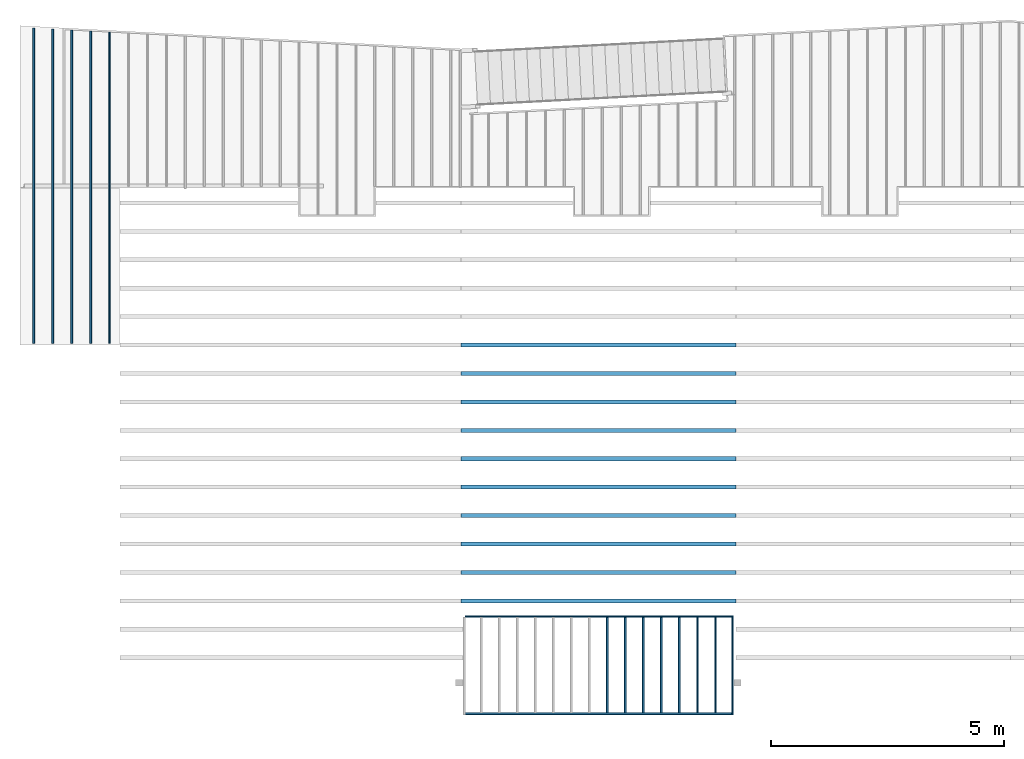
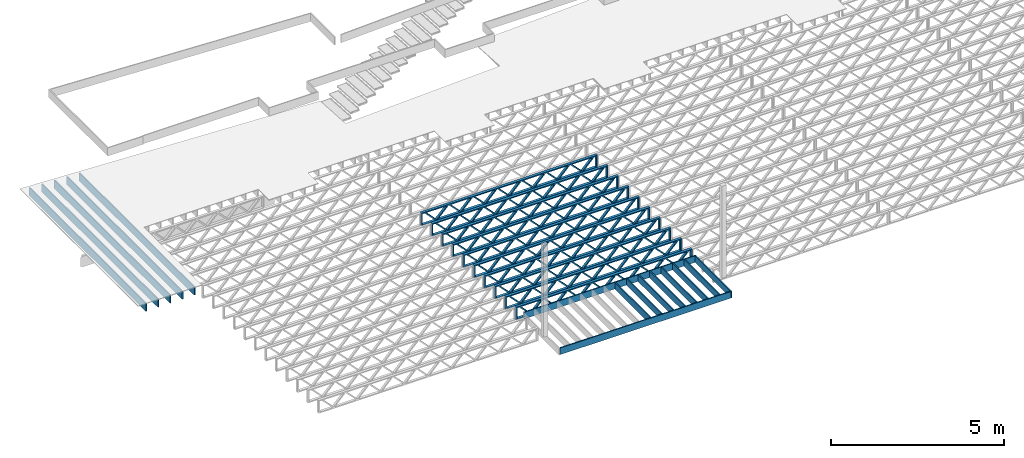
# One storey, part 2 of 23: 25 beams, 3 elements without a shape of their own.
"""IFC4 building model written with IfcOpenShell, lengths in feet."""

from ifc_helpers import new_model, entity, si_unit, converted_unit, derived_unit, direction, frame, frame_2d, origin, origin_2d_with_axis, place, context, subcontext, project, spatial, rectangle, extrude, source, transform, mapped, material, material_profile, profile_set, profile_usage, type_object, type_shapes, element, aggregate, save


model = new_model("IFC4")

# Units and contexts
model_context = context("Model", 3, precision=0.0001, world=origin(), true_north=direction((6.12303176911189e-17, 1.0)))
body_context = subcontext(model_context, "Body", "Model", "MODEL_VIEW")
ifc_project = project(units=[converted_unit("LENGTHUNIT", "FOOT", entity("IfcRatioMeasure", 0.3048), si_unit("LENGTHUNIT", "METRE"), dimensions=[1, 0, 0, 0, 0, 0, 0]), converted_unit("AREAUNIT", "SQUARE FOOT", entity("IfcRatioMeasure", 0.09290304), si_unit("AREAUNIT", "SQUARE_METRE"), dimensions=[2, 0, 0, 0, 0, 0, 0]), converted_unit("VOLUMEUNIT", "CUBIC FOOT", entity("IfcRatioMeasure", 0.028316846592), si_unit("VOLUMEUNIT", "CUBIC_METRE"), dimensions=[3, 0, 0, 0, 0, 0, 0]), converted_unit("PLANEANGLEUNIT", "DEGREE", entity("IfcRatioMeasure", 0.0174532925199433), si_unit("PLANEANGLEUNIT", "RADIAN"), dimensions=[0, 0, 0, 0, 0, 0, 0]), si_unit("MASSUNIT", "GRAM", prefix="KILO"), derived_unit("MASSDENSITYUNIT", [(si_unit("MASSUNIT", "GRAM", prefix="KILO"), 1), (si_unit("LENGTHUNIT", "METRE"), -3)]), derived_unit("MOMENTOFINERTIAUNIT", [(si_unit("LENGTHUNIT", "METRE"), 4)]), si_unit("TIMEUNIT", "SECOND"), si_unit("FREQUENCYUNIT", "HERTZ"), si_unit("THERMODYNAMICTEMPERATUREUNIT", "DEGREE_CELSIUS"), derived_unit("THERMALTRANSMITTANCEUNIT", [(si_unit("MASSUNIT", "GRAM", prefix="KILO"), 1), (si_unit("THERMODYNAMICTEMPERATUREUNIT", "KELVIN"), -1), (si_unit("TIMEUNIT", "SECOND"), -3)]), derived_unit("VOLUMETRICFLOWRATEUNIT", [(si_unit("LENGTHUNIT", "METRE"), 3), (si_unit("TIMEUNIT", "SECOND"), -1)]), si_unit("ELECTRICCURRENTUNIT", "AMPERE"), si_unit("ELECTRICVOLTAGEUNIT", "VOLT"), si_unit("POWERUNIT", "WATT"), si_unit("FORCEUNIT", "NEWTON"), si_unit("ILLUMINANCEUNIT", "LUX"), si_unit("LUMINOUSFLUXUNIT", "LUMEN"), si_unit("LUMINOUSINTENSITYUNIT", "CANDELA"), derived_unit("USERDEFINED", [(si_unit("MASSUNIT", "GRAM", prefix="KILO"), -1), (si_unit("LENGTHUNIT", "METRE"), -2), (si_unit("TIMEUNIT", "SECOND"), 3), (si_unit("LUMINOUSFLUXUNIT", "LUMEN"), 1)]), derived_unit("LINEARVELOCITYUNIT", [(si_unit("LENGTHUNIT", "METRE"), 1), (si_unit("TIMEUNIT", "SECOND"), -1)]), si_unit("PRESSUREUNIT", "PASCAL"), derived_unit("USERDEFINED", [(si_unit("LENGTHUNIT", "METRE"), -2), (si_unit("MASSUNIT", "GRAM", prefix="KILO"), 1), (si_unit("TIMEUNIT", "SECOND"), -2)]), derived_unit("LINEARFORCEUNIT", [(si_unit("MASSUNIT", "GRAM", prefix="KILO"), 1), (si_unit("LENGTHUNIT", "METRE"), 1), (si_unit("TIMEUNIT", "SECOND"), -2), (si_unit("LENGTHUNIT", "METRE"), -1)]), derived_unit("PLANARFORCEUNIT", [(si_unit("MASSUNIT", "GRAM", prefix="KILO"), 1), (si_unit("LENGTHUNIT", "METRE"), 1), (si_unit("TIMEUNIT", "SECOND"), -2), (si_unit("LENGTHUNIT", "METRE"), -2)])], contexts=[model_context])

# Site, building, storey
site_placement = place(None, origin())
site = spatial("IfcSite", under=ifc_project, at=site_placement, CompositionType="ELEMENT")
building_placement = place(site_placement, origin())
building = spatial("IfcBuilding", under=site, at=building_placement, CompositionType="ELEMENT")
storey_placement = place(building_placement, frame((0.0, 0.0, 10.8020833333333)))
storey = spatial("IfcBuildingStorey", under=building, at=storey_placement, Name="2ND FLOOR", CompositionType="ELEMENT", Elevation=10.8020833333333)

# Assembly, beams
assembly_1_placement = place(storey_placement, origin())
assembly_1 = element("IfcElementAssembly", 1, at=assembly_1_placement, inside=storey, Name="Structural Beam System:Structural Framing System", ObjectType="Structural Beam System:Structural Framing System", AssemblyPlace="NOTDEFINED", PredefinedType="BEAM_GRID")
ifc_material_1 = material(Category="Materials")
ifc_material_profile_1 = material_profile(ifc_material_1, rectangle(XDim=0.770833333333333, YDim=0.124999999999994, at=frame_2d((-5.55111512312578e-17, 0.0), x_axis=(1.0, 0.0))))
ifc_profile_set_1 = profile_set([ifc_material_profile_1])
ifc_profile_usage_1 = profile_usage(ifc_profile_set_1, cardinal=8)
beam_type_1 = type_object("IfcBeamType", PredefinedType="BEAM", material=ifc_profile_set_1)
shared_shape_1 = source(origin(), body_context, "Body", "SweptSolid", [
    extrude(rectangle(XDim=0.770833333333333, YDim=0.124999999999994, at=frame_2d((-5.55111512312578e-17, 0.0), x_axis=(1.0, 0.0))), frame((-3.35416666666737, 0.0, 0.0), z_axis=(1.0, 0.0, 0.0), x_axis=(0.0, 0.0, -1.0)), (0.0, 0.0, 1.0), 6.70833333333462),
])
type_shapes(beam_type_1, [shared_shape_1])
beam_1_placement = place(assembly_1_placement, frame((-231.439678851187, 925.341101549318, -0.645833333333433), z_axis=(0.0, 0.0, 1.0), x_axis=(0.0, 1.0, 0.0)))
beam_1 = element("IfcBeam", 2, at=beam_1_placement, type_object=beam_type_1, material=ifc_profile_usage_1, PredefinedType="BEAM", context=body_context, shape_type="MappedRepresentation", body=[
    mapped(shared_shape_1, transform((0.0, 0.0, 0.0), scale=1.0)),
])
ifc_profile_usage_2 = profile_usage(ifc_profile_set_1, cardinal=8)
beam_2_placement = place(assembly_1_placement, frame((-230.172795170628, 925.341101549318, -0.645833333333471), z_axis=(0.0, 0.0, 1.0), x_axis=(0.0, 1.0, 0.0)))
beam_2 = element("IfcBeam", 3, at=beam_2_placement, type_object=beam_type_1, material=ifc_profile_usage_2, PredefinedType="BEAM", context=body_context, shape_type="MappedRepresentation", body=[
    mapped(shared_shape_1, transform((0.0, 0.0, 0.0), scale=1.0)),
])
ifc_profile_usage_3 = profile_usage(ifc_profile_set_1, cardinal=8)
beam_3_placement = place(assembly_1_placement, frame((-228.90591149007, 925.341101549318, -0.645833333333471), z_axis=(0.0, 0.0, 1.0), x_axis=(0.0, 1.0, 0.0)))
beam_3 = element("IfcBeam", 4, at=beam_3_placement, type_object=beam_type_1, material=ifc_profile_usage_3, PredefinedType="BEAM", context=body_context, shape_type="MappedRepresentation", body=[
    mapped(shared_shape_1, transform((0.0, 0.0, 0.0), scale=1.0)),
])
ifc_profile_usage_4 = profile_usage(ifc_profile_set_1, cardinal=8)
beam_4_placement = place(assembly_1_placement, frame((-227.639027809511, 925.341101549318, -0.645833333333471), z_axis=(0.0, 0.0, 1.0), x_axis=(0.0, 1.0, 0.0)))
beam_4 = element("IfcBeam", 5, at=beam_4_placement, type_object=beam_type_1, material=ifc_profile_usage_4, PredefinedType="BEAM", context=body_context, shape_type="MappedRepresentation", body=[
    mapped(shared_shape_1, transform((0.0, 0.0, 0.0), scale=1.0)),
])
ifc_profile_usage_5 = profile_usage(ifc_profile_set_1, cardinal=8)
beam_5_placement = place(assembly_1_placement, frame((-226.372144128953, 925.341101549318, -0.645833333333471), z_axis=(0.0, 0.0, 1.0), x_axis=(0.0, 1.0, 0.0)))
beam_5 = element("IfcBeam", 6, at=beam_5_placement, type_object=beam_type_1, material=ifc_profile_usage_5, PredefinedType="BEAM", context=body_context, shape_type="MappedRepresentation", body=[
    mapped(shared_shape_1, transform((0.0, 0.0, 0.0), scale=1.0)),
])
ifc_profile_usage_6 = profile_usage(ifc_profile_set_1, cardinal=8)
beam_6_placement = place(assembly_1_placement, frame((-225.105260448395, 925.341101549318, -0.645833333333471), z_axis=(0.0, 0.0, 1.0), x_axis=(0.0, 1.0, 0.0)))
beam_6 = element("IfcBeam", 7, at=beam_6_placement, type_object=beam_type_1, material=ifc_profile_usage_6, PredefinedType="BEAM", context=body_context, shape_type="MappedRepresentation", body=[
    mapped(shared_shape_1, transform((0.0, 0.0, 0.0), scale=1.0)),
])
ifc_profile_usage_7 = profile_usage(ifc_profile_set_1, cardinal=8)
beam_7_placement = place(assembly_1_placement, frame((-223.838376767836, 925.341101549319, -0.645833333333471), z_axis=(0.0, 0.0, 1.0), x_axis=(0.0, 1.0, 0.0)))
beam_7 = element("IfcBeam", 8, at=beam_7_placement, type_object=beam_type_1, material=ifc_profile_usage_7, PredefinedType="BEAM", context=body_context, shape_type="MappedRepresentation", body=[
    mapped(shared_shape_1, transform((0.0, 0.0, 0.0), scale=1.0)),
])
aggregate(assembly_1, [beam_1, beam_2, beam_3, beam_4, beam_5, beam_6, beam_7])

assembly_2_placement = place(storey_placement, origin())
assembly_2 = element("IfcElementAssembly", 9, at=assembly_2_placement, inside=storey, Name="Structural Beam System:Structural Framing System", ObjectType="Structural Beam System:Structural Framing System", AssemblyPlace="NOTDEFINED", PredefinedType="BEAM_GRID")
ifc_material_2 = material(Name="WOOD TRUSS", Category="Materials")
ifc_material_profile_2 = material_profile(ifc_material_2, rectangle(XDim=1.73473973950632, YDim=0.125, at=frame_2d((-1.11022302462516e-16, 8.32667268468867e-17), x_axis=(1.0, 0.0))))
ifc_material_profile_3 = material_profile(ifc_material_2, rectangle(XDim=1.73473973950633, YDim=0.125, at=frame_2d((-1.11022302462516e-16, 8.32667268468867e-17), x_axis=(1.0, 0.0))))
ifc_material_profile_4 = material_profile(ifc_material_2, rectangle(XDim=1.73473973950632, YDim=0.125, at=frame_2d((-5.55111512312578e-17, 1.38777878078145e-16), x_axis=(1.0, 0.0))))
ifc_material_profile_5 = material_profile(ifc_material_2, rectangle(XDim=1.73473973950633, YDim=0.125, at=frame_2d((-1.11022302462516e-16, 8.32667268468867e-17), x_axis=(1.0, 0.0))))
ifc_material_profile_6 = material_profile(ifc_material_2, rectangle(XDim=1.73473973950632, YDim=0.125, at=frame_2d((-1.11022302462516e-16, 8.32667268468867e-17), x_axis=(1.0, 0.0))))
ifc_material_profile_7 = material_profile(ifc_material_2, rectangle(XDim=1.73473973950633, YDim=0.125, at=frame_2d((-2.77555756156289e-16, 3.05311331771918e-16), x_axis=(1.0, 0.0))))
ifc_material_profile_8 = material_profile(ifc_material_2, rectangle(XDim=1.73473973950632, YDim=0.124999999999999, at=frame_2d((-3.88578058618805e-16, -2.4980018054066e-16), x_axis=(1.0, 0.0))))
ifc_material_profile_9 = material_profile(ifc_material_2, rectangle(XDim=1.73473973950633, YDim=0.125, at=frame_2d((2.77555756156289e-16, -3.05311331771918e-16), x_axis=(1.0, 0.0))))
ifc_material_profile_10 = material_profile(ifc_material_2, rectangle(XDim=1.73473973950632, YDim=0.124999999999999, at=frame_2d((-1.11022302462516e-16, 8.32667268468867e-17), x_axis=(1.0, 0.0))))
ifc_material_profile_11 = material_profile(ifc_material_2, rectangle(XDim=1.73473973950633, YDim=0.125, at=origin_2d_with_axis()))
ifc_material_profile_12 = material_profile(ifc_material_2, rectangle(XDim=0.124999999999982, YDim=0.291666666666668, at=origin_2d_with_axis()))
ifc_material_profile_13 = material_profile(ifc_material_2, rectangle(XDim=0.124999999999932, YDim=0.291666666666664, at=origin_2d_with_axis()))
ifc_material_profile_14 = material_profile(ifc_material_2, rectangle(XDim=1.25000000000002, YDim=0.29166666666667, at=origin_2d_with_axis()))
ifc_material_profile_15 = material_profile(ifc_material_2, rectangle(XDim=1.25000000000004, YDim=0.291666666666667, at=origin_2d_with_axis()))
ifc_profile_set_2 = profile_set([ifc_material_profile_2, ifc_material_profile_3, ifc_material_profile_4, ifc_material_profile_5, ifc_material_profile_6, ifc_material_profile_7, ifc_material_profile_8, ifc_material_profile_9, ifc_material_profile_10, ifc_material_profile_11, ifc_material_profile_12, ifc_material_profile_13, ifc_material_profile_14, ifc_material_profile_15])
ifc_profile_usage_8 = profile_usage(ifc_profile_set_2, cardinal=8)
beam_type_2 = type_object("IfcBeamType", PredefinedType="BEAM", material=ifc_profile_set_2)
shared_shape_2 = source(origin(), body_context, "Body", "SweptSolid", [
    extrude(rectangle(XDim=1.73473973950632, YDim=0.124999999999999, at=frame_2d((5.55111512312578e-16, 7.21644966006352e-16), x_axis=(1.0, 0.0))), frame((5.95847627016997, -0.145833333333334, 0.0), z_axis=(0.0, 1.0, 0.0), x_axis=(0.693383046997606, 0.0, 0.720569184836762)), (0.0, 0.0, 1.0), 0.291666666666667),
    extrude(rectangle(XDim=1.73473973950633, YDim=0.125, at=origin_2d_with_axis()), frame((4.7081903964967, -0.145833333333334, 0.0), z_axis=(0.0, 1.0, 0.0), x_axis=(0.69338304699761, 0.0, -0.720569184836758)), (0.0, 0.0, 1.0), 0.291666666666666),
    extrude(rectangle(XDim=1.73473973950632, YDim=0.125, at=frame_2d((2.22044604925031e-16, 3.88578058618805e-16), x_axis=(1.0, 0.0))), frame((3.29180960350347, -0.145833333333334, 0.0), z_axis=(0.0, 1.0, 0.0), x_axis=(0.693383046997606, 0.0, 0.720569184836762)), (0.0, 0.0, 1.0), 0.291666666666667),
    extrude(rectangle(XDim=1.73473973950633, YDim=0.125, at=frame_2d((1.11022302462516e-16, -8.32667268468867e-17), x_axis=(1.0, 0.0))), frame((2.0415237298302, -0.145833333333334, 0.0), z_axis=(0.0, 1.0, 0.0), x_axis=(0.69338304699761, 0.0, -0.720569184836758)), (0.0, 0.0, 1.0), 0.291666666666667),
    extrude(rectangle(XDim=1.73473973950632, YDim=0.125, at=frame_2d((-5.55111512312578e-17, 1.38777878078145e-16), x_axis=(1.0, 0.0))), frame((0.625142936836964, -0.145833333333334, 0.0), z_axis=(0.0, 1.0, 0.0), x_axis=(0.693383046997606, 0.0, 0.720569184836762)), (0.0, 0.0, 1.0), 0.291666666666667),
    extrude(rectangle(XDim=1.73473973950633, YDim=0.125, at=frame_2d((-1.11022302462516e-16, 8.32667268468867e-17), x_axis=(1.0, 0.0))), frame((-0.625142936836306, -0.145833333333334, 0.0), z_axis=(0.0, 1.0, 0.0), x_axis=(0.69338304699761, 0.0, -0.720569184836758)), (0.0, 0.0, 1.0), 0.291666666666667),
    extrude(rectangle(XDim=1.73473973950632, YDim=0.125, at=frame_2d((-1.11022302462516e-16, 8.32667268468867e-17), x_axis=(1.0, 0.0))), frame((-2.04152372982954, -0.145833333333334, 0.0), z_axis=(0.0, 1.0, 0.0), x_axis=(0.693383046997606, 0.0, 0.720569184836762)), (0.0, 0.0, 1.0), 0.291666666666667),
    extrude(rectangle(XDim=1.73473973950633, YDim=0.125, at=origin_2d_with_axis()), frame((-3.29180960350281, -0.145833333333334, 0.0), z_axis=(0.0, 1.0, 0.0), x_axis=(0.69338304699761, 0.0, -0.720569184836758)), (0.0, 0.0, 1.0), 0.291666666666667),
    extrude(rectangle(XDim=1.73473973950632, YDim=0.124999999999999, at=frame_2d((-1.11022302462516e-16, 8.32667268468867e-17), x_axis=(1.0, 0.0))), frame((-4.70819039649604, -0.145833333333334, 0.0), z_axis=(0.0, 1.0, 0.0), x_axis=(0.693383046997606, 0.0, 0.720569184836762)), (0.0, 0.0, 1.0), 0.291666666666667),
    extrude(rectangle(XDim=1.73473973950633, YDim=0.125, at=frame_2d((-5.55111512312578e-16, 6.38378239159465e-16), x_axis=(1.0, 0.0))), frame((-5.95847627016931, -0.145833333333334, 0.0), z_axis=(0.0, 1.0, 0.0), x_axis=(0.69338304699761, 0.0, -0.720569184836758)), (0.0, 0.0, 1.0), 0.291666666666666),
    extrude(rectangle(XDim=1.73473973950632, YDim=0.125, at=frame_2d((-7.21644966006352e-16, -5.82867087928207e-16), x_axis=(1.0, 0.0))), frame((8.62514293683647, -0.145833333333334, 0.0), z_axis=(0.0, 1.0, 0.0), x_axis=(0.693383046997607, 0.0, 0.720569184836761)), (0.0, 0.0, 1.0), 0.291666666666667),
    extrude(rectangle(XDim=1.73473973950633, YDim=0.125, at=origin_2d_with_axis()), frame((7.3748570631632, -0.145833333333334, 0.0), z_axis=(0.0, 1.0, 0.0), x_axis=(0.69338304699761, 0.0, -0.720569184836758)), (0.0, 0.0, 1.0), 0.291666666666666),
    extrude(rectangle(XDim=1.73473973950632, YDim=0.124999999999999, at=frame_2d((-1.11022302462516e-16, 8.32667268468867e-17), x_axis=(1.0, 0.0))), frame((-7.37485706316255, -0.145833333333334, 0.0), z_axis=(0.0, 1.0, 0.0), x_axis=(0.693383046997606, 0.0, 0.720569184836762)), (0.0, 0.0, 1.0), 0.291666666666667),
    extrude(rectangle(XDim=1.73473973950633, YDim=0.125, at=origin_2d_with_axis()), frame((-8.62514293683582, -0.145833333333334, 0.0), z_axis=(0.0, 1.0, 0.0), x_axis=(0.69338304699761, 0.0, -0.720569184836758)), (0.0, 0.0, 1.0), 0.291666666666666),
    extrude(rectangle(XDim=0.124999999999982, YDim=0.291666666666668, at=origin_2d_with_axis()), frame((-9.66666666666609, 0.0, 0.687500000000054), z_axis=(1.0, 0.0, 0.0), x_axis=(0.0, 0.0, -1.0)), (0.0, 0.0, 1.0), 19.3333333333322),
    extrude(rectangle(XDim=0.124999999999932, YDim=0.291666666666664, at=origin_2d_with_axis()), frame((-9.66666666666588, 0.0, -0.687499999999984), z_axis=(1.0, 0.0, 0.0), x_axis=(0.0, 0.0, -1.0)), (0.0, 0.0, 1.0), 19.333333333332),
    extrude(rectangle(XDim=1.25000000000002, YDim=0.29166666666667, at=origin_2d_with_axis()), frame((9.54166666666607, 0.0, 0.0), z_axis=(1.0, 0.0, 0.0), x_axis=(0.0, 0.0, -1.0)), (0.0, 0.0, 1.0), 0.12500000000002),
    extrude(rectangle(XDim=1.25000000000004, YDim=0.291666666666667, at=origin_2d_with_axis()), frame((-9.66666666666609, 0.0, 0.0), z_axis=(1.0, 0.0, 0.0), x_axis=(0.0, 0.0, -1.0)), (0.0, 0.0, 1.0), 0.125000000000023),
])
type_shapes(beam_type_2, [shared_shape_2])
beam_8_placement = place(assembly_2_placement, frame((-232.071493788723, 947.861934882651, -0.947916666666657)))
beam_8 = element("IfcBeam", 10, at=beam_8_placement, type_object=beam_type_2, material=ifc_profile_usage_8, PredefinedType="BEAM", context=body_context, shape_type="MappedRepresentation", body=[
    mapped(shared_shape_2, transform((0.0, 0.0, 0.0), scale=1.0)),
])
ifc_profile_usage_9 = profile_usage(ifc_profile_set_2, cardinal=8)
beam_9_placement = place(assembly_2_placement, frame((-232.071493788723, 945.861934882651, -0.947916666666657)))
beam_9 = element("IfcBeam", 11, at=beam_9_placement, type_object=beam_type_2, material=ifc_profile_usage_9, PredefinedType="BEAM", context=body_context, shape_type="MappedRepresentation", body=[
    mapped(shared_shape_2, transform((0.0, 0.0, 0.0), scale=1.0)),
])
ifc_profile_usage_10 = profile_usage(ifc_profile_set_2, cardinal=8)
beam_10_placement = place(assembly_2_placement, frame((-232.071493788723, 943.861934882651, -0.947916666666657)))
beam_10 = element("IfcBeam", 12, at=beam_10_placement, type_object=beam_type_2, material=ifc_profile_usage_10, PredefinedType="BEAM", context=body_context, shape_type="MappedRepresentation", body=[
    mapped(shared_shape_2, transform((0.0, 0.0, 0.0), scale=1.0)),
])
ifc_profile_usage_11 = profile_usage(ifc_profile_set_2, cardinal=8)
beam_11_placement = place(assembly_2_placement, frame((-232.071493788723, 941.861934882651, -0.947916666666657)))
beam_11 = element("IfcBeam", 13, at=beam_11_placement, type_object=beam_type_2, material=ifc_profile_usage_11, PredefinedType="BEAM", context=body_context, shape_type="MappedRepresentation", body=[
    mapped(shared_shape_2, transform((0.0, 0.0, 0.0), scale=1.0)),
])
ifc_profile_usage_12 = profile_usage(ifc_profile_set_2, cardinal=8)
beam_12_placement = place(assembly_2_placement, frame((-232.071493788723, 939.861934882651, -0.947916666666657)))
beam_12 = element("IfcBeam", 14, at=beam_12_placement, type_object=beam_type_2, material=ifc_profile_usage_12, PredefinedType="BEAM", context=body_context, shape_type="MappedRepresentation", body=[
    mapped(shared_shape_2, transform((0.0, 0.0, 0.0), scale=1.0)),
])
ifc_profile_usage_13 = profile_usage(ifc_profile_set_2, cardinal=8)
beam_13_placement = place(assembly_2_placement, frame((-232.071493788723, 937.861934882651, -0.947916666666657)))
beam_13 = element("IfcBeam", 15, at=beam_13_placement, type_object=beam_type_2, material=ifc_profile_usage_13, PredefinedType="BEAM", context=body_context, shape_type="MappedRepresentation", body=[
    mapped(shared_shape_2, transform((0.0, 0.0, 0.0), scale=1.0)),
])
ifc_profile_usage_14 = profile_usage(ifc_profile_set_2, cardinal=8)
beam_14_placement = place(assembly_2_placement, frame((-232.071493788723, 935.861934882651, -0.947916666666657)))
beam_14 = element("IfcBeam", 16, at=beam_14_placement, type_object=beam_type_2, material=ifc_profile_usage_14, PredefinedType="BEAM", context=body_context, shape_type="MappedRepresentation", body=[
    mapped(shared_shape_2, transform((0.0, 0.0, 0.0), scale=1.0)),
])
ifc_profile_usage_15 = profile_usage(ifc_profile_set_2, cardinal=8)
beam_15_placement = place(assembly_2_placement, frame((-232.071493788723, 933.861934882651, -0.947916666666657)))
beam_15 = element("IfcBeam", 17, at=beam_15_placement, type_object=beam_type_2, material=ifc_profile_usage_15, PredefinedType="BEAM", context=body_context, shape_type="MappedRepresentation", body=[
    mapped(shared_shape_2, transform((0.0, 0.0, 0.0), scale=1.0)),
])
ifc_profile_usage_16 = profile_usage(ifc_profile_set_2, cardinal=8)
beam_16_placement = place(assembly_2_placement, frame((-232.071493788723, 931.861934882651, -0.947916666666657)))
beam_16 = element("IfcBeam", 18, at=beam_16_placement, type_object=beam_type_2, material=ifc_profile_usage_16, PredefinedType="BEAM", context=body_context, shape_type="MappedRepresentation", body=[
    mapped(shared_shape_2, transform((0.0, 0.0, 0.0), scale=1.0)),
])
ifc_profile_usage_17 = profile_usage(ifc_profile_set_2, cardinal=8)
beam_17_placement = place(assembly_2_placement, frame((-232.071493788723, 929.861934882651, -0.947916666666657)))
beam_17 = element("IfcBeam", 19, at=beam_17_placement, type_object=beam_type_2, material=ifc_profile_usage_17, PredefinedType="BEAM", context=body_context, shape_type="MappedRepresentation", body=[
    mapped(shared_shape_2, transform((0.0, 0.0, 0.0), scale=1.0)),
])
aggregate(assembly_2, [beam_8, beam_9, beam_10, beam_11, beam_12, beam_13, beam_14, beam_15, beam_16, beam_17])

assembly_3_placement = place(storey_placement, origin())
assembly_3 = element("IfcElementAssembly", 20, at=assembly_3_placement, inside=storey, Name="Structural Beam System:Structural Framing System", ObjectType="Structural Beam System:Structural Framing System", AssemblyPlace="NOTDEFINED", PredefinedType="BEAM_GRID")
ifc_material_profile_16 = material_profile(ifc_material_1, rectangle(XDim=0.9375, YDim=0.125000000000011, at=origin_2d_with_axis()))
ifc_profile_set_3 = profile_set([ifc_material_profile_16])
ifc_profile_usage_18 = profile_usage(ifc_profile_set_3, cardinal=8)
beam_type_3 = type_object("IfcBeamType", PredefinedType="BEAM", material=ifc_profile_set_3)
shared_shape_3 = source(origin(), body_context, "Body", "SweptSolid", [
    extrude(rectangle(XDim=0.9375, YDim=0.125000000000011, at=origin_2d_with_axis()), frame((-11.0859100543191, 0.0, 0.0), z_axis=(1.0, 0.0, 0.0), x_axis=(0.0, 0.0, -1.0)), (0.0, 0.0, 1.0), 22.1718201086381),
])
type_shapes(beam_type_3, [shared_shape_3])
beam_18_placement = place(assembly_3_placement, frame((-271.800660485462, 959.07284493697, -0.729166666666744), z_axis=(0.0, 0.0, 1.0), x_axis=(0.0, 1.0, 0.0)))
beam_18 = element("IfcBeam", 21, at=beam_18_placement, type_object=beam_type_3, material=ifc_profile_usage_18, PredefinedType="BEAM", context=body_context, shape_type="MappedRepresentation", body=[
    mapped(shared_shape_3, transform((0.0, 0.0, 0.0), scale=1.0)),
])
ifc_profile_usage_19 = profile_usage(ifc_profile_set_3, cardinal=8)
beam_type_4 = type_object("IfcBeamType", PredefinedType="BEAM", material=ifc_profile_set_3)
shared_shape_4 = source(origin(), body_context, "Body", "SweptSolid", [
    extrude(rectangle(XDim=0.9375, YDim=0.125000000000011, at=origin_2d_with_axis()), frame((-11.050971534797, 0.0, 0.0), z_axis=(1.0, 0.0, 0.0), x_axis=(0.0, 0.0, -1.0)), (0.0, 0.0, 1.0), 22.1019430695941),
])
type_shapes(beam_type_4, [shared_shape_4])
beam_19_placement = place(assembly_3_placement, frame((-270.467327152129, 959.037906417448, -0.729166666666744), z_axis=(0.0, 0.0, 1.0), x_axis=(0.0, 1.0, 0.0)))
beam_19 = element("IfcBeam", 22, at=beam_19_placement, type_object=beam_type_4, material=ifc_profile_usage_19, PredefinedType="BEAM", context=body_context, shape_type="MappedRepresentation", body=[
    mapped(shared_shape_4, transform((0.0, 0.0, 0.0), scale=1.0)),
])
ifc_profile_usage_20 = profile_usage(ifc_profile_set_3, cardinal=8)
beam_type_5 = type_object("IfcBeamType", PredefinedType="BEAM", material=ifc_profile_set_3)
shared_shape_5 = source(origin(), body_context, "Body", "SweptSolid", [
    extrude(rectangle(XDim=0.9375, YDim=0.125000000000011, at=origin_2d_with_axis()), frame((-11.016033015275, 0.0, 0.0), z_axis=(1.0, 0.0, 0.0), x_axis=(0.0, 0.0, -1.0)), (0.0, 0.0, 1.0), 22.03206603055),
])
type_shapes(beam_type_5, [shared_shape_5])
beam_20_placement = place(assembly_3_placement, frame((-269.133993818795, 959.002967897926, -0.729166666666744), z_axis=(0.0, 0.0, 1.0), x_axis=(0.0, 1.0, 0.0)))
beam_20 = element("IfcBeam", 23, at=beam_20_placement, type_object=beam_type_5, material=ifc_profile_usage_20, PredefinedType="BEAM", context=body_context, shape_type="MappedRepresentation", body=[
    mapped(shared_shape_5, transform((0.0, 0.0, 0.0), scale=1.0)),
])
ifc_profile_usage_21 = profile_usage(ifc_profile_set_3, cardinal=8)
beam_type_6 = type_object("IfcBeamType", PredefinedType="BEAM", material=ifc_profile_set_3)
shared_shape_6 = source(origin(), body_context, "Body", "SweptSolid", [
    extrude(rectangle(XDim=0.9375, YDim=0.125000000000011, at=origin_2d_with_axis()), frame((-10.981094495753, 0.0, 0.0), z_axis=(1.0, 0.0, 0.0), x_axis=(0.0, 0.0, -1.0)), (0.0, 0.0, 1.0), 21.962188991506),
])
type_shapes(beam_type_6, [shared_shape_6])
beam_21_placement = place(assembly_3_placement, frame((-267.800660485462, 958.968029378404, -0.729166666666744), z_axis=(0.0, 0.0, 1.0), x_axis=(0.0, 1.0, 0.0)))
beam_21 = element("IfcBeam", 24, at=beam_21_placement, type_object=beam_type_6, material=ifc_profile_usage_21, PredefinedType="BEAM", context=body_context, shape_type="MappedRepresentation", body=[
    mapped(shared_shape_6, transform((0.0, 0.0, 0.0), scale=1.0)),
])
ifc_profile_usage_22 = profile_usage(ifc_profile_set_3, cardinal=8)
beam_type_7 = type_object("IfcBeamType", PredefinedType="BEAM", material=ifc_profile_set_3)
shared_shape_7 = source(origin(), body_context, "Body", "SweptSolid", [
    extrude(rectangle(XDim=0.9375, YDim=0.125000000000011, at=origin_2d_with_axis()), frame((-10.946155976231, 0.0, 0.0), z_axis=(1.0, 0.0, 0.0), x_axis=(0.0, 0.0, -1.0)), (0.0, 0.0, 1.0), 21.8923119524619),
])
type_shapes(beam_type_7, [shared_shape_7])
beam_22_placement = place(assembly_3_placement, frame((-266.467327152129, 958.933090858882, -0.729166666666744), z_axis=(0.0, 0.0, 1.0), x_axis=(0.0, 1.0, 0.0)))
beam_22 = element("IfcBeam", 25, at=beam_22_placement, type_object=beam_type_7, material=ifc_profile_usage_22, PredefinedType="BEAM", context=body_context, shape_type="MappedRepresentation", body=[
    mapped(shared_shape_7, transform((0.0, 0.0, 0.0), scale=1.0)),
])
aggregate(assembly_3, [beam_18, beam_19, beam_20, beam_21, beam_22])

# Beams
ifc_profile_usage_23 = profile_usage(ifc_profile_set_1, cardinal=8)
beam_type_8 = type_object("IfcBeamType", PredefinedType="BEAM", material=ifc_profile_set_1)
shared_shape_8 = source(origin(), body_context, "Body", "SweptSolid", [
    extrude(rectangle(XDim=0.770833333333333, YDim=0.124999999999994, at=origin_2d_with_axis()), frame((-3.47916666666737, 0.0, 0.0), z_axis=(1.0, 0.0, 0.0), x_axis=(0.0, 0.0, -1.0)), (0.0, 0.0, 1.0), 6.83333333333471),
])
type_shapes(beam_type_8, [shared_shape_8])
beam_23_placement = place(storey_placement, frame((-222.633996063824, 925.341101549319, -0.645833333333512), z_axis=(0.0, 0.0, 1.0), x_axis=(0.0, 1.0, 0.0)))
element("IfcBeam", 26, at=beam_23_placement, inside=storey, type_object=beam_type_8, material=ifc_profile_usage_23, PredefinedType="BEAM", context=body_context, shape_type="MappedRepresentation", body=[
    mapped(shared_shape_8, transform((0.0, 0.0, 0.0), scale=1.0)),
])
ifc_profile_usage_24 = profile_usage(ifc_profile_set_1, cardinal=8)
beam_type_9 = type_object("IfcBeamType", PredefinedType="BEAM", material=ifc_profile_set_1)
shared_shape_9 = source(origin(), body_context, "Body", "SweptSolid", [
    extrude(rectangle(XDim=0.770833333333333, YDim=0.124999999999994, at=origin_2d_with_axis()), frame((-9.49999887751909, 0.0, 0.0), z_axis=(1.0, 0.0, 0.0), x_axis=(0.0, 0.0, -1.0)), (0.0, 0.0, 1.0), 18.8749977550383),
])
type_shapes(beam_type_9, [shared_shape_9])
beam_24_placement = place(storey_placement, frame((-232.071494941343, 928.757768215985, -0.645833333333506), z_axis=(0.0, 0.0, 1.0), x_axis=(-1.0, 0.0, 0.0)))
element("IfcBeam", 27, at=beam_24_placement, inside=storey, type_object=beam_type_9, material=ifc_profile_usage_24, PredefinedType="BEAM", context=body_context, shape_type="MappedRepresentation", body=[
    mapped(shared_shape_9, transform((0.0, 0.0, 0.0), scale=1.0)),
])
ifc_material_3 = material(Name="BRAKE METAL FLASHING AT PERIMETER 2X LEDGER", Category="Materials")
ifc_material_profile_17 = material_profile(ifc_material_3, rectangle(XDim=0.770833333333333, YDim=0.124999999999994, at=frame_2d((-1.11022302462516e-16, 0.0), x_axis=(1.0, 0.0))), Name="BRAKE METAL FLASHING AT PERIMETER 2X LEDGER")
ifc_profile_set_4 = profile_set([ifc_material_profile_17], Name="BRAKE METAL FLASHING AT PERIMETER 2X LEDGER")
ifc_profile_usage_25 = profile_usage(ifc_profile_set_4, cardinal=8)
beam_type_10 = type_object("IfcBeamType", PredefinedType="BEAM", material=ifc_profile_set_4)
shared_shape_10 = source(origin(), body_context, "Body", "SweptSolid", [
    extrude(rectangle(XDim=0.770833333333333, YDim=0.124999999999994, at=origin_2d_with_axis()), frame((-9.37499887751909, 0.0, 0.0), z_axis=(1.0, 0.0, 0.0), x_axis=(0.0, 0.0, -1.0)), (0.0, 0.0, 1.0), 18.7499977550382),
])
type_shapes(beam_type_10, [shared_shape_10])
beam_25_placement = place(storey_placement, frame((-232.071494941343, 921.92443488265, -0.645833333333494), z_axis=(0.0, 0.0, 1.0), x_axis=(-1.0, 0.0, 0.0)))
element("IfcBeam", 28, at=beam_25_placement, inside=storey, type_object=beam_type_10, material=ifc_profile_usage_25, PredefinedType="BEAM", context=body_context, shape_type="MappedRepresentation", body=[
    mapped(shared_shape_10, transform((0.0, 0.0, 0.0), scale=1.0)),
])

save(model, "model.ifc")
